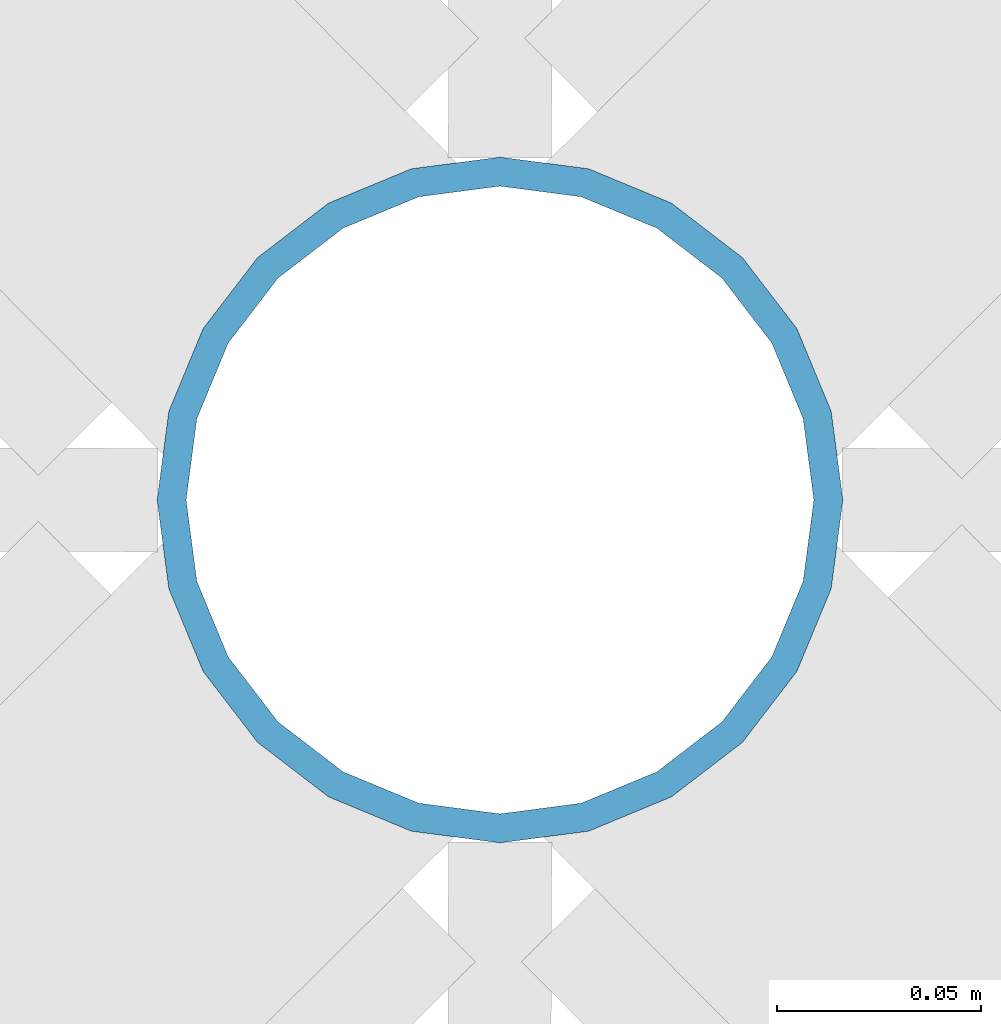
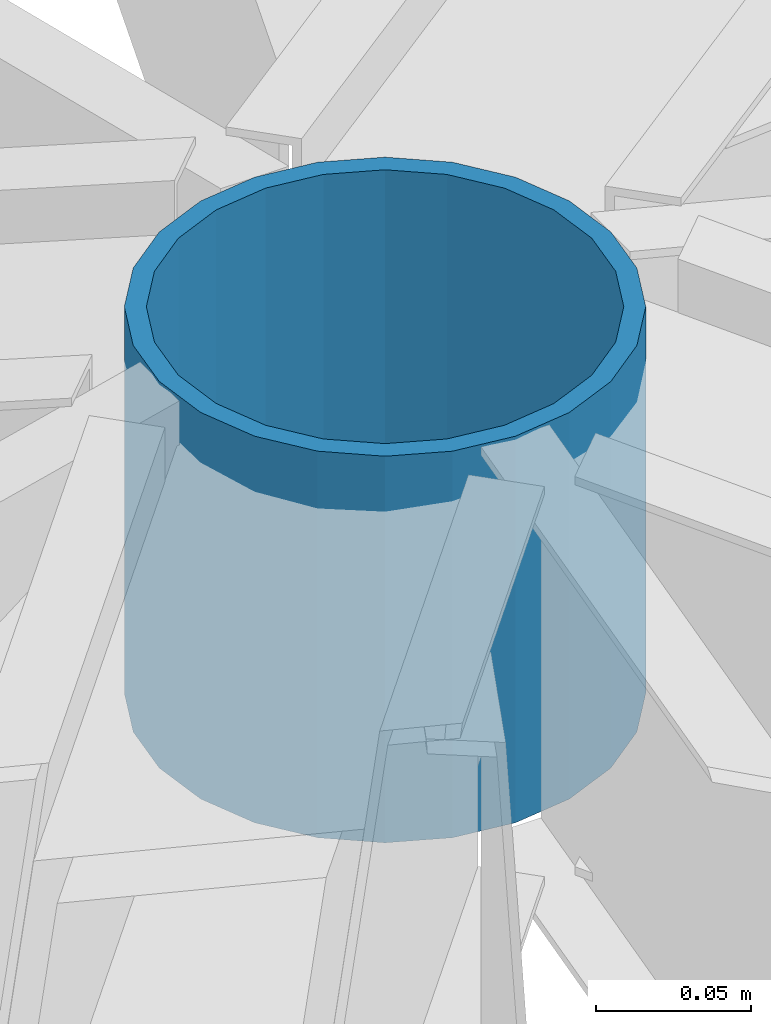
# One storey, part 260 of 975: 1 column.
"""IFC2X3 building model written with IfcOpenShell, lengths in millimetres."""

from ifc_helpers import new_model, si_unit, frame, origin_with_axes, place, context, subcontext, project, spatial, faceted_brep, material, type_object, element, save


model = new_model("IFC2X3")

# Units and contexts
model_context = context("Model", 3, precision=1e-05, world=origin_with_axes())
body_context = subcontext(model_context, "Body", "Model", "MODEL_VIEW")
ifc_project = project(units=[si_unit("LENGTHUNIT", "METRE", prefix="MILLI"), si_unit("AREAUNIT", "SQUARE_METRE"), si_unit("VOLUMEUNIT", "CUBIC_METRE"), si_unit("MASSUNIT", "GRAM", prefix="KILO"), si_unit("TIMEUNIT", "SECOND"), si_unit("PLANEANGLEUNIT", "RADIAN"), si_unit("SOLIDANGLEUNIT", "STERADIAN"), si_unit("THERMODYNAMICTEMPERATUREUNIT", "DEGREE_CELSIUS"), si_unit("LUMINOUSINTENSITYUNIT", "LUMEN")], contexts=[model_context])

# Site, building, storey
site_placement = place(None, origin_with_axes())
site = spatial("IfcSite", under=ifc_project, at=site_placement, CompositionType="ELEMENT")
building_placement = place(site_placement, origin_with_axes())
building = spatial("IfcBuilding", under=site, at=building_placement, Name="Undefined", CompositionType="ELEMENT")
storey_placement = place(building_placement, origin_with_axes())
storey = spatial("IfcBuildingStorey", under=building, at=storey_placement, Name="Undefined", CompositionType="ELEMENT", Elevation=0.0)

# Column
ifc_material = material(Name="STEEL/A53")
column_type = type_object("IfcColumnType", Name="PIPE6STD", PredefinedType="NOTDEFINED")
column_placement = place(storey_placement, frame((34734.5, 3403.59999999999, 9106.58570695336), z_axis=(0.0, 1.0, 0.0), x_axis=(0.0, 0.0, 1.0)))
element("IfcColumn", 1, at=column_placement, inside=storey, type_object=column_type, material=ifc_material, Name="BEAM", ObjectType="PIPE6STD", context=body_context, shape_type="Brep", body=[
    faceted_brep([(0.0, -77.0889999999999, 0.0), (0.0, -74.4622560227945, 19.9521013679082), (152.4, -74.4622560227945, 19.9521013679082), (152.4, -77.0889999999999, 0.0), (0.0, -66.7610323523404, 38.5445), (152.4, -66.7610323523404, 38.5445), (0.0, -54.5101546548904, 54.5101546548899), (152.4, -54.5101546548904, 54.5101546548899), (0.0, -38.5444999999963, 66.7610323523386), (152.4, -38.5444999999963, 66.7610323523386), (0.0, -19.9521013679114, 74.4622560227981), (152.4, -19.9521013679114, 74.4622560227981), (0.0, 0.0, 77.0889999999999), (152.4, 0.0, 77.0889999999999), (0.0, 19.9521013679114, 74.4622560227981), (152.4, 19.9521013679114, 74.4622560227981), (0.0, 38.5445000000036, 66.7610323523386), (152.4, 38.5445000000036, 66.7610323523386), (0.0, 54.5101546548904, 54.5101546548899), (152.4, 54.5101546548904, 54.5101546548899), (0.0, 66.7610323523404, 38.5445), (152.4, 66.7610323523404, 38.5445), (0.0, 74.4622560227945, 19.9521013679082), (152.4, 74.4622560227945, 19.9521013679082), (0.0, 77.0889999999999, 0.0), (152.4, 77.0889999999999, 0.0), (0.0, 74.4622560227945, -19.9521013679082), (152.4, 74.4622560227945, -19.9521013679082), (0.0, 66.7610323523404, -38.5445), (152.4, 66.7610323523404, -38.5445), (0.0, 54.5101546548904, -54.5101546548899), (152.4, 54.5101546548904, -54.5101546548899), (0.0, 38.5445000000036, -66.7610323523386), (152.4, 38.5445000000036, -66.7610323523386), (0.0, 19.9521013679114, -74.4622560227981), (152.4, 19.9521013679114, -74.4622560227981), (0.0, 0.0, -77.0889999999999), (152.4, 0.0, -77.0889999999999), (0.0, -19.9521013679114, -74.4622560227981), (152.4, -19.9521013679114, -74.4622560227981), (0.0, -38.5445000000036, -66.7610323523386), (152.4, -38.5445000000036, -66.7610323523386), (0.0, -54.5101546548904, -54.5101546548899), (152.4, -54.5101546548904, -54.5101546548899), (0.0, -66.7610323523404, -38.5445), (152.4, -66.7610323523404, -38.5445), (0.0, -74.4622560227945, -19.9521013679082), (152.4, -74.4622560227945, -19.9521013679082), (0.0, -84.2010000000009, 0.0), (0.0, -81.3319204993677, -21.7928224166776), (152.4, -81.3319204993677, -21.7928224166776), (152.4, -84.2010000000009, 0.0), (0.0, -72.9202050240565, -42.1005), (152.4, -72.9202050240565, -42.1005), (0.0, -59.5390980826851, -59.5390980826883), (152.4, -59.5390980826851, -59.5390980826883), (0.0, -42.1005000000005, -72.9202050240538), (152.4, -42.1005000000005, -72.9202050240538), (0.0, -21.7928224166753, -81.3319204993659), (152.4, -21.7928224166753, -81.3319204993659), (0.0, 0.0, -84.201), (152.4, 0.0, -84.201), (0.0, 21.7928224166753, -81.3319204993659), (152.4, 21.7928224166753, -81.3319204993659), (0.0, 42.1005000000005, -72.9202050240533), (152.4, 42.1005000000005, -72.9202050240533), (0.0, 59.5390980826851, -59.5390980826883), (152.4, 59.5390980826851, -59.5390980826883), (0.0, 72.9202050240565, -42.1005), (152.4, 72.9202050240565, -42.1005), (0.0, 81.3319204993677, -21.7928224166772), (152.4, 81.3319204993677, -21.7928224166772), (0.0, 84.2010000000009, 0.0), (152.4, 84.2010000000009, 0.0), (0.0, 81.3319204993677, 21.7928224166772), (152.4, 81.3319204993677, 21.7928224166772), (0.0, 72.9202050240565, 42.1005), (152.4, 72.9202050240565, 42.1005), (0.0, 59.5390980826851, 59.5390980826883), (152.4, 59.5390980826851, 59.5390980826883), (0.0, 42.1005000000005, 72.9202050240533), (152.4, 42.1005000000005, 72.9202050240533), (0.0, 21.7928224166753, 81.3319204993659), (152.4, 21.7928224166753, 81.3319204993659), (0.0, 0.0, 84.201), (152.4, 0.0, 84.201), (0.0, -21.7928224166753, 81.3319204993659), (152.4, -21.7928224166753, 81.3319204993659), (0.0, -42.1005000000005, 72.9202050240533), (152.4, -42.1005000000005, 72.9202050240533), (0.0, -59.5390980826851, 59.5390980826883), (152.4, -59.5390980826851, 59.5390980826883), (0.0, -72.9202050240565, 42.1005), (152.4, -72.9202050240565, 42.1005), (0.0, -81.3319204993677, 21.7928224166772), (152.4, -81.3319204993677, 21.7928224166772)], [[[0, 1, 2, 3]], [[1, 4, 5, 2]], [[4, 6, 7, 5]], [[6, 8, 9, 7]], [[8, 10, 11, 9]], [[10, 12, 13, 11]], [[12, 14, 15, 13]], [[14, 16, 17, 15]], [[16, 18, 19, 17]], [[18, 20, 21, 19]], [[20, 22, 23, 21]], [[22, 24, 25, 23]], [[24, 26, 27, 25]], [[26, 28, 29, 27]], [[28, 30, 31, 29]], [[30, 32, 33, 31]], [[32, 34, 35, 33]], [[34, 36, 37, 35]], [[36, 38, 39, 37]], [[38, 40, 41, 39]], [[40, 42, 43, 41]], [[42, 44, 45, 43]], [[44, 46, 47, 45]], [[46, 0, 3, 47]], [[48, 49, 50, 51]], [[49, 52, 53, 50]], [[52, 54, 55, 53]], [[54, 56, 57, 55]], [[56, 58, 59, 57]], [[58, 60, 61, 59]], [[60, 62, 63, 61]], [[62, 64, 65, 63]], [[64, 66, 67, 65]], [[66, 68, 69, 67]], [[68, 70, 71, 69]], [[70, 72, 73, 71]], [[72, 74, 75, 73]], [[74, 76, 77, 75]], [[76, 78, 79, 77]], [[78, 80, 81, 79]], [[80, 82, 83, 81]], [[82, 84, 85, 83]], [[84, 86, 87, 85]], [[86, 88, 89, 87]], [[88, 90, 91, 89]], [[90, 92, 93, 91]], [[92, 94, 95, 93]], [[94, 48, 51, 95]], [[53, 55, 57, 59, 61, 63, 65, 67, 69, 71, 73, 75, 77, 79, 81, 83, 85, 87, 89, 91, 93, 95, 51, 50], [5, 7, 9, 11, 13, 15, 17, 19, 21, 23, 25, 27, 29, 31, 33, 35, 37, 39, 41, 43, 45, 47, 3, 2]], [[94, 92, 90, 88, 86, 84, 82, 80, 78, 76, 74, 72, 70, 68, 66, 64, 62, 60, 58, 56, 54, 52, 49, 48], [46, 44, 42, 40, 38, 36, 34, 32, 30, 28, 26, 24, 22, 20, 18, 16, 14, 12, 10, 8, 6, 4, 1, 0]]]),
])

save(model, "model.ifc")
